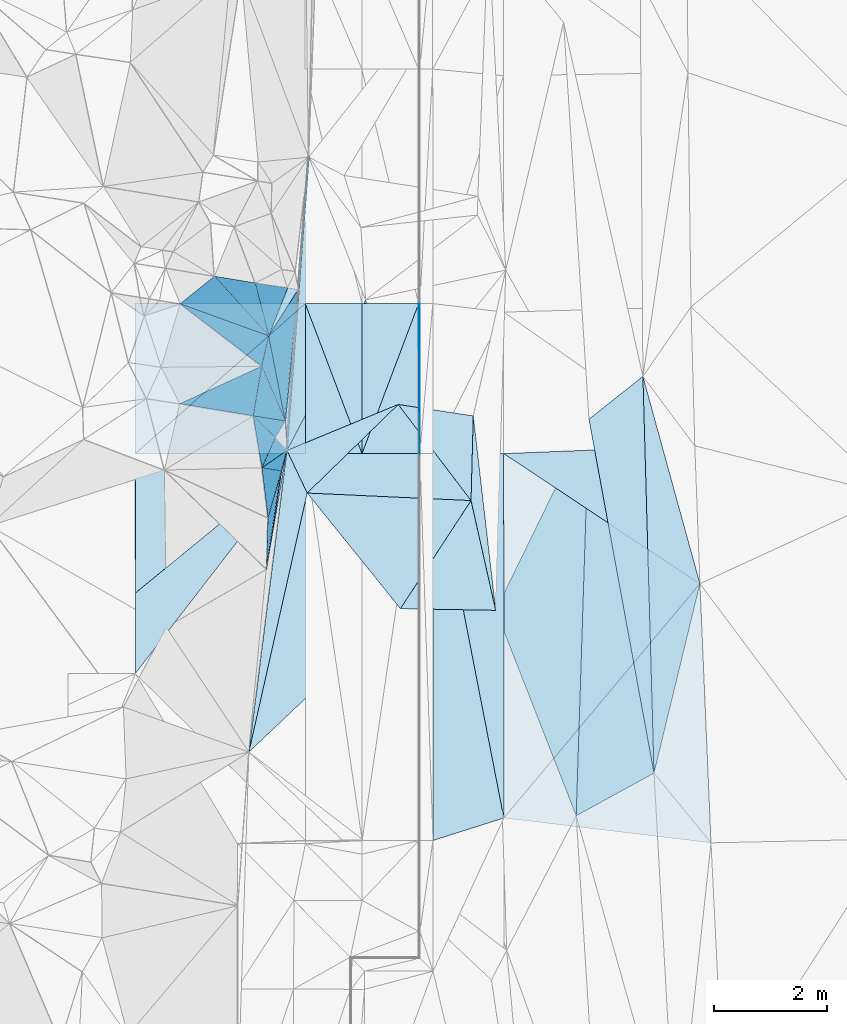
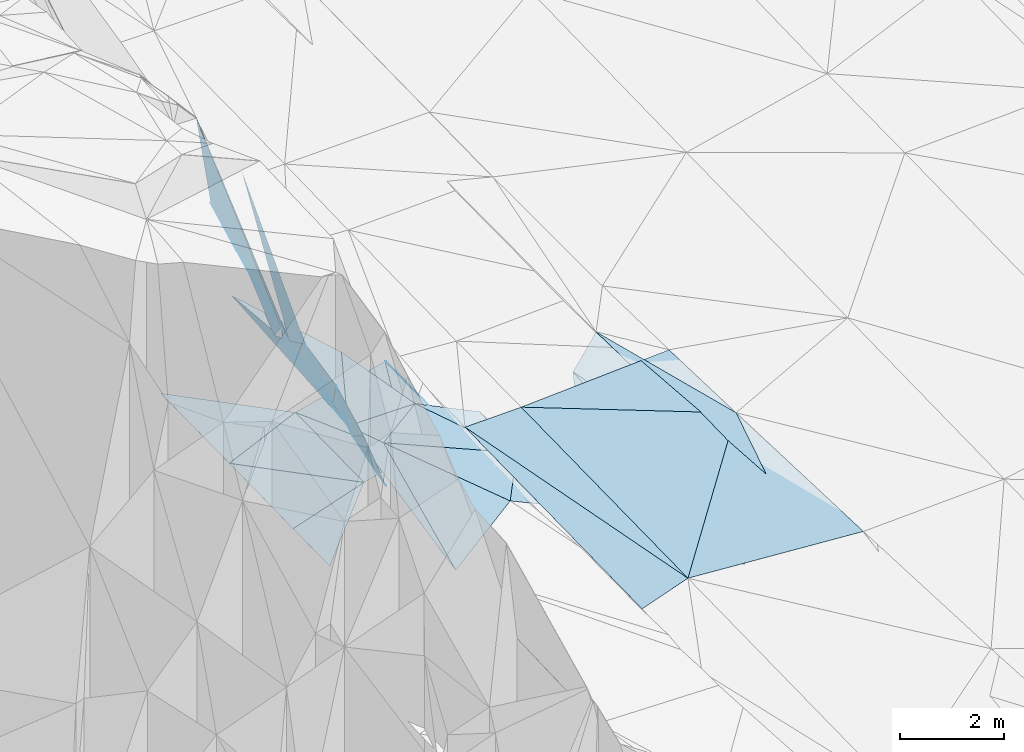
# One storey, part 130 of 275: 46 plates.
"""IFC2X3 building model written with IfcOpenShell, lengths in millimetres."""

from ifc_helpers import new_model, si_unit, frame, origin_with_axes, place, context, subcontext, project, spatial, polyline, outline, extrude, material, type_object, element, save


model = new_model("IFC2X3")

# Units and contexts
model_context = context("Model", 3, precision=1e-05, world=origin_with_axes())
body_context = subcontext(model_context, "Body", "Model", "MODEL_VIEW")
ifc_project = project(units=[si_unit("LENGTHUNIT", "METRE", prefix="MILLI"), si_unit("AREAUNIT", "SQUARE_METRE"), si_unit("VOLUMEUNIT", "CUBIC_METRE"), si_unit("MASSUNIT", "GRAM", prefix="KILO"), si_unit("TIMEUNIT", "SECOND"), si_unit("PLANEANGLEUNIT", "RADIAN"), si_unit("SOLIDANGLEUNIT", "STERADIAN"), si_unit("THERMODYNAMICTEMPERATUREUNIT", "DEGREE_CELSIUS"), si_unit("LUMINOUSINTENSITYUNIT", "LUMEN")], contexts=[model_context])

# Site, building, storey
site_placement = place(None, origin_with_axes())
site = spatial("IfcSite", under=ifc_project, at=site_placement, CompositionType="ELEMENT")
building_placement = place(site_placement, origin_with_axes())
building = spatial("IfcBuilding", under=site, at=building_placement, Name="Undefined", CompositionType="ELEMENT")
storey_placement = place(building_placement, origin_with_axes())
storey = spatial("IfcBuildingStorey", under=building, at=storey_placement, Name="Undefined", CompositionType="ELEMENT", Elevation=0.0)

# Plates
ifc_material = material()
plate_type_1 = type_object("IfcPlateType", PredefinedType="NOTDEFINED")
plate_1_placement = place(storey_placement, frame((-94153.5739844034, 105995.146812893, 43130.8232980734), z_axis=(0.0278374764460999, 0.0206402043385478, -0.999399348043602), x_axis=(-0.952600541112338, -0.302452734080232, -0.0327803709538701)))
element("IfcPlate", 1, at=plate_1_placement, inside=storey, type_object=plate_type_1, material=ifc_material, Name="00_PR", context=body_context, shape_type="SweptSolid", body=[
    extrude(outline(polyline([(0.0, 0.0), (1312.06567382813, 6.79574441164732e-09), (-754.560241699219, 6505.60107421875), (0.0, 0.0)])), frame((-8.85201319254618e-08, 2.18876761149539e-07, -0.5000001331573), z_axis=(0.0, 0.0, 1.0), x_axis=(1.0, 0.0, 0.0)), (0.0, 0.0, 1.0), 1.0),
])
plate_2_placement = place(storey_placement, frame((-95405.6369415542, 112422.818515543, 43228.6962711666), z_axis=(0.0261208683010833, 0.0203066313521981, -0.999452520614323), x_axis=(0.999658249521957, 0.000510879081040791, 0.0261366249784056)))
element("IfcPlate", 2, at=plate_2_placement, inside=storey, type_object=plate_type_1, material=ifc_material, Name="00_PR", context=body_context, shape_type="SweptSolid", body=[
    extrude(outline(polyline([(0.0, 0.0), (1250.42919921875, -1.22236087918282e-09), (1245.79235839844, 6429.634765625), (0.0, 0.0)])), frame((-8.85201319254618e-08, 2.18876761149539e-07, -0.5000001331573), z_axis=(0.0, 0.0, 1.0), x_axis=(1.0, 0.0, 0.0)), (0.0, 0.0, 1.0), 1.0),
])
plate_type_2 = type_object("IfcPlateType", PredefinedType="NOTDEFINED")
plate_3_placement = place(storey_placement, frame((-95656.4742749567, 115069.463045143, 43260.2196910795), z_axis=(0.0499247074951265, 0.0166259598819332, -0.998614590840496), x_axis=(0.998752315665235, 0.000325866070990781, 0.0499370179790064)))
element("IfcPlate", 3, at=plate_3_placement, inside=storey, type_object=plate_type_2, material=ifc_material, Name="00_PR", context=body_context, shape_type="SweptSolid", body=[
    extrude(outline(polyline([(0.0, 0.0), (20.0252170562744, 7.18500814400613e-11), (17.8119373321533, 2647.0927734375), (0.0, 0.0)])), frame((-8.85201319254618e-08, 2.18876761149539e-07, -0.5000001331573), z_axis=(0.0, 0.0, 1.0), x_axis=(1.0, 0.0, 0.0)), (0.0, 0.0, 1.0), 1.0),
])
plate_type_3 = type_object("IfcPlateType", PredefinedType="NOTDEFINED")
plate_4_placement = place(storey_placement, frame((-99872.0650010797, 113302.814362502, 50299.8591237515), z_axis=(-0.959496805873995, 0.00234955808764443, -0.281709707135544), x_axis=(0.279685924124985, 0.127877033033819, -0.951537307870175)))
element("IfcPlate", 4, at=plate_4_placement, inside=storey, type_object=plate_type_3, material=ifc_material, Name="00", context=body_context, shape_type="SweptSolid", body=[
    extrude(outline(polyline([(0.0, 0.0), (5170.580078125, 9.32777766138315e-09), (4541.27001953125, 801.042053222656), (0.0, 0.0)])), frame((-8.85201319254618e-08, 2.18876761149539e-07, -0.5000001331573), z_axis=(0.0, 0.0, 1.0), x_axis=(1.0, 0.0, 0.0)), (0.0, 0.0, 1.0), 1.0),
])
plate_type_4 = type_object("IfcPlateType", PredefinedType="NOTDEFINED")
plate_5_placement = place(storey_placement, frame((-99864.5274643564, 115066.554479282, 50459.8470441327), z_axis=(-0.932356227712419, 0.192760558500819, -0.305867997234626), x_axis=(0.290269002138026, -0.105254291932914, -0.95113902266046)))
element("IfcPlate", 5, at=plate_5_placement, inside=storey, type_object=plate_type_4, material=ifc_material, Name="00", context=body_context, shape_type="SweptSolid", body=[
    extrude(outline(polyline([(0.0, 0.0), (5383.01953125, -1.00408215075731e-08), (5365.40869140625, 551.171325683594), (0.0, 0.0)])), frame((-8.85201319254618e-08, 2.18876761149539e-07, -0.5000001331573), z_axis=(0.0, 0.0, 1.0), x_axis=(1.0, 0.0, 0.0)), (0.0, 0.0, 1.0), 1.0),
])
plate_6_placement = place(storey_placement, frame((-99259.4282691992, 115552.712917861, 47959.8037929451), z_axis=(-0.907265399754033, 0.151375251563829, -0.39237103310915), x_axis=(0.387097684267183, -0.0641139159434348, -0.919806930076841)))
element("IfcPlate", 6, at=plate_6_placement, inside=storey, type_object=plate_type_4, material=ifc_material, Name="00", context=body_context, shape_type="SweptSolid", body=[
    extrude(outline(polyline([(0.0, 0.0), (1859.08581542969, 4.30736690759659e-09), (2848.0126953125, 882.169799804688), (0.0, 0.0)])), frame((-8.85201319254618e-08, 2.18876761149539e-07, -0.5000001331573), z_axis=(0.0, 0.0, 1.0), x_axis=(1.0, 0.0, 0.0)), (0.0, 0.0, 1.0), 1.0),
])
plate_type_5 = type_object("IfcPlateType", PredefinedType="NOTDEFINED")
plate_7_placement = place(storey_placement, frame((-100655.082924783, 109962.813485595, 44165.7136786777), z_axis=(-0.442612464401428, 0.0113191605245592, -0.896641557681504), x_axis=(0.724348482389604, 0.5939477153815, -0.350064833213756)))
element("IfcPlate", 7, at=plate_7_placement, inside=storey, type_object=plate_type_5, material=ifc_material, Name="00_PR", context=body_context, shape_type="SweptSolid", body=[
    extrude(outline(polyline([(0.0, 0.0), (4140.564453125, 2.29920260608196e-08), (-836.783935546875, 1147.52770996094), (0.0, 0.0)])), frame((-8.85201319254618e-08, 2.18876761149539e-07, -0.5000001331573), z_axis=(0.0, 0.0, 1.0), x_axis=(1.0, 0.0, 0.0)), (0.0, 0.0, 1.0), 1.0),
])
plate_type_6 = type_object("IfcPlateType", PredefinedType="NOTDEFINED")
plate_8_placement = place(storey_placement, frame((-97655.8736261931, 112422.095734692, 42716.2488614941), z_axis=(-0.447143922811431, 0.0182397050018191, -0.894276034261375), x_axis=(-0.7243484823853, -0.593947715386519, 0.350064833214145)))
element("IfcPlate", 8, at=plate_8_placement, inside=storey, type_object=plate_type_6, material=ifc_material, Name="00_PR", context=body_context, shape_type="SweptSolid", body=[
    extrude(outline(polyline([(0.0, 0.0), (4140.564453125, 2.29920260608196e-08), (2698.71362304688, 1991.71862792969), (0.0, 0.0)])), frame((-8.85201319254618e-08, 2.18876761149539e-07, -0.5000001331573), z_axis=(0.0, 0.0, 1.0), x_axis=(1.0, 0.0, 0.0)), (0.0, 0.0, 1.0), 1.0),
])
plate_type_7 = type_object("IfcPlateType", PredefinedType="NOTDEFINED")
for number, where, z_axis, x_axis, name in (
    (9, (-100655.873251657, 112421.132227227, 44216.2488349393), (-0.447168887781171, 0.0147320316862256, -0.894328213265659), (0.704464317565349, 0.621909904733936, -0.341991367831139), "00_PR"),
    (10, (-97656.7219843052, 115068.820453759, 42760.2718346619), (-0.447168887781171, 0.0147320316862256, -0.894328213265659), (-0.704464318025631, -0.621909904093813, 0.341991368047072), "00_PR"),
):
    element("IfcPlate", number, at=place(storey_placement, frame(where, z_axis=z_axis, x_axis=x_axis)), inside=storey, type_object=plate_type_7, material=ifc_material, Name=name, context=body_context, shape_type="SweptSolid", body=[
        extrude(outline(polyline([(0.0, 0.0), (4257.35009765625, 1.80443748831749e-08), (2626.97778320313, 2085.42236328125), (0.0, 0.0)])), frame((-8.85201319254618e-08, 2.18876761149539e-07, -0.5000001331573), z_axis=(0.0, 0.0, 1.0), x_axis=(1.0, 0.0, 0.0)), (0.0, 0.0, 1.0), 1.0),
    ])
plate_type_8 = type_object("IfcPlateType", PredefinedType="NOTDEFINED")
for number, where, z_axis, x_axis, name in (
    (11, (-96655.5287662428, 112422.415747409, 42966.2109910744), (0.242498842736958, 0.0162120063965467, -0.97001622776108), (-0.970142403271045, -0.000311047105442569, -0.242535813077531), "00_PR"),
    (12, (-97656.3771468638, 115068.821194078, 42760.2339911808), (0.242498842736958, 0.0162120063965467, -0.97001622776108), (0.970142455388523, 0.000311440077304942, 0.242535604103411), "00_PR"),
):
    element("IfcPlate", number, at=place(storey_placement, frame(where, z_axis=z_axis, x_axis=x_axis)), inside=storey, type_object=plate_type_8, material=ifc_material, Name=name, context=body_context, shape_type="SweptSolid", body=[
        extrude(outline(polyline([(0.0, 0.0), (1030.77648925781, -5.90807758271694e-09), (1020.09808349609, 2647.07104492188), (0.0, 0.0)])), frame((-8.85201319254618e-08, 2.18876761149539e-07, -0.5000001331573), z_axis=(0.0, 0.0, 1.0), x_axis=(1.0, 0.0, 0.0)), (0.0, 0.0, 1.0), 1.0),
    ])
plate_type_9 = type_object("IfcPlateType", PredefinedType="NOTDEFINED")
plate_9_placement = place(storey_placement, frame((-95656.3779866372, 115069.462839216, 43260.2339901821), z_axis=(0.242498842736958, 0.0162120063965467, -0.97001622776108), x_axis=(0.00032097805931429, -0.999861648908334, -0.0166306949762518)))
element("IfcPlate", 13, at=plate_9_placement, inside=storey, type_object=plate_type_9, material=ifc_material, Name="00_PR", context=body_context, shape_type="SweptSolid", body=[
    extrude(outline(polyline([(0.0, 0.0), (2647.09326171875, -9.60426405072212e-09), (2651.25, 1030.7685546875), (0.0, 0.0)])), frame((-8.85201319254618e-08, 2.18876761149539e-07, -0.5000001331573), z_axis=(0.0, 0.0, 1.0), x_axis=(1.0, 0.0, 0.0)), (0.0, 0.0, 1.0), 1.0),
])
plate_10_placement = place(storey_placement, frame((-96655.5287662428, 112422.415747409, 42966.2109910744), z_axis=(0.242498842736958, 0.0162120063965467, -0.97001622776108), x_axis=(-0.000320480057325893, 0.999861649018139, 0.0166306979787731)))
element("IfcPlate", 14, at=plate_10_placement, inside=storey, type_object=plate_type_9, material=ifc_material, Name="00_PR", context=body_context, shape_type="SweptSolid", body=[
    extrude(outline(polyline([(0.0, 0.0), (2647.0927734375, 1.41153577715158e-08), (2651.25048828125, 1030.76721191406), (0.0, 0.0)])), frame((-8.85201319254618e-08, 2.18876761149539e-07, -0.5000001331573), z_axis=(0.0, 0.0, 1.0), x_axis=(1.0, 0.0, 0.0)), (0.0, 0.0, 1.0), 1.0),
])
plate_type_10 = type_object("IfcPlateType", PredefinedType="NOTDEFINED")
plate_11_placement = place(storey_placement, frame((-98574.8625320658, 113089.061324221, 45879.8370640157), z_axis=(-0.945089085803476, -0.025316928593437, -0.325830742904572), x_axis=(0.146212636792908, 0.858897229716422, -0.490833386830523)))
element("IfcPlate", 15, at=plate_11_placement, inside=storey, type_object=plate_type_10, material=ifc_material, Name="00", context=body_context, shape_type="SweptSolid", body=[
    extrude(outline(polyline([(0.0, 0.0), (1018.67559814453, -3.98722477257252e-09), (805.752075195313, 1527.79699707031), (0.0, 0.0)])), frame((-8.85201319254618e-08, 2.18876761149539e-07, -0.5000001331573), z_axis=(0.0, 0.0, 1.0), x_axis=(1.0, 0.0, 0.0)), (0.0, 0.0, 1.0), 1.0),
])
plate_type_11 = type_object("IfcPlateType", PredefinedType="NOTDEFINED")
plate_12_placement = place(storey_placement, frame((-96592.5799105062, 115135.16011891, 43769.5112733669), z_axis=(-0.210295943601626, -0.0212414963958179, -0.977406985311425), x_axis=(-0.459428561301201, -0.880344137005874, 0.117981343864573)))
element("IfcPlate", 16, at=plate_12_placement, inside=storey, type_object=plate_type_11, material=ifc_material, Name="00", context=body_context, shape_type="SweptSolid", body=[
    extrude(outline(polyline([(0.0, 0.0), (3017.42626953125, 6.66477717459202e-09), (-1736.73779296875, 2086.4150390625), (0.0, 0.0)])), frame((-8.85201319254618e-08, 2.18876761149539e-07, -0.5000001331573), z_axis=(0.0, 0.0, 1.0), x_axis=(1.0, 0.0, 0.0)), (0.0, 0.0, 1.0), 1.0),
])
plate_type_12 = type_object("IfcPlateType", PredefinedType="NOTDEFINED")
plate_13_placement = place(storey_placement, frame((-90785.0571654086, 112559.415552066, 43349.5002529591), z_axis=(0.0253446032108164, 0.0194983356069369, -0.999488602234486), x_axis=(0.0372663191023117, -0.999133250256122, -0.0185464199564918)))
element("IfcPlate", 17, at=plate_13_placement, inside=storey, type_object=plate_type_12, material=ifc_material, Name="00_PR", context=body_context, shape_type="SweptSolid", body=[
    extrude(outline(polyline([(0.0, 0.0), (2433.0302734375, 3.52156348526478e-09), (11.8660821914673, 3374.44921875), (0.0, 0.0)])), frame((-8.85201319254618e-08, 2.18876761149539e-07, -0.5000001331573), z_axis=(0.0, 0.0, 1.0), x_axis=(1.0, 0.0, 0.0)), (0.0, 0.0, 1.0), 1.0),
])
plate_type_13 = type_object("IfcPlateType", PredefinedType="NOTDEFINED")
plate_14_placement = place(storey_placement, frame((-90694.3864496484, 110128.494231487, 43304.3762713233), z_axis=(0.0266141804198783, 0.0196921245479067, -0.999451802555465), x_axis=(0.0426336240944424, -0.998918619030197, -0.0185463379506328)))
element("IfcPlate", 18, at=plate_14_placement, inside=storey, type_object=plate_type_13, material=ifc_material, Name="00_PR", context=body_context, shape_type="SweptSolid", body=[
    extrude(outline(polyline([(0.0, 0.0), (4576.42919921875, -1.27183739095926e-08), (3984.619140625, 3633.65893554688), (0.0, 0.0)])), frame((-8.85201319254618e-08, 2.18876761149539e-07, -0.5000001331573), z_axis=(0.0, 0.0, 1.0), x_axis=(1.0, 0.0, 0.0)), (0.0, 0.0, 1.0), 1.0),
])
plate_type_14 = type_object("IfcPlateType", PredefinedType="NOTDEFINED")
plate_15_placement = place(storey_placement, frame((-94153.5749686622, 105995.146645917, 43130.8232688278), z_axis=(0.0258802024209601, 0.0203066816319356, -0.99945878044257), x_axis=(-0.000320420084066932, 0.99979377701162, 0.0203051909571934)))
element("IfcPlate", 19, at=plate_15_placement, inside=storey, type_object=plate_type_14, material=ifc_material, Name="00_PR", context=body_context, shape_type="SweptSolid", body=[
    extrude(outline(polyline([(0.0, 0.0), (6429.63671875, -3.37604433298111e-08), (4134.9111328125, 3461.67260742188), (0.0, 0.0)])), frame((-8.85201319254618e-08, 2.18876761149539e-07, -0.5000001331573), z_axis=(0.0, 0.0, 1.0), x_axis=(1.0, 0.0, 0.0)), (0.0, 0.0, 1.0), 1.0),
])
plate_type_15 = type_object("IfcPlateType", PredefinedType="NOTDEFINED")
plate_16_placement = place(storey_placement, frame((-97978.9340204413, 112478.82157642, 44125.5294730019), z_axis=(-0.334843187766478, 0.0486332055852855, -0.941017986502321), x_axis=(0.459428561388022, 0.880344136960672, -0.11798134386377)))
element("IfcPlate", 20, at=plate_16_placement, inside=storey, type_object=plate_type_15, material=ifc_material, Name="00", context=body_context, shape_type="SweptSolid", body=[
    extrude(outline(polyline([(0.0, 0.0), (3017.42626953125, 6.66477717459202e-09), (1692.81384277344, 1438.81970214844), (0.0, 0.0)])), frame((-8.85201319254618e-08, 2.18876761149539e-07, -0.5000001331573), z_axis=(0.0, 0.0, 1.0), x_axis=(1.0, 0.0, 0.0)), (0.0, 0.0, 1.0), 1.0),
])
plate_type_16 = type_object("IfcPlateType", PredefinedType="NOTDEFINED")
plate_17_placement = place(storey_placement, frame((-92652.0111202408, 113030.752163405, 43197.5049582611), z_axis=(0.138826511348324, 0.0229762009720196, -0.990050147182327), x_axis=(0.77733346851035, 0.616884155337105, 0.123315115163132)))
element("IfcPlate", 21, at=plate_17_placement, inside=storey, type_object=plate_type_16, material=ifc_material, Name="00", context=body_context, shape_type="SweptSolid", body=[
    extrude(outline(polyline([(0.0, 0.0), (1224.50524902344, -2.03726813197136e-09), (-2957.46240234375, 5616.72265625), (0.0, 0.0)])), frame((-8.85201319254618e-08, 2.18876761149539e-07, -0.5000001331573), z_axis=(0.0, 0.0, 1.0), x_axis=(1.0, 0.0, 0.0)), (0.0, 0.0, 1.0), 1.0),
])
plate_type_17 = type_object("IfcPlateType", PredefinedType="NOTDEFINED")
plate_18_placement = place(storey_placement, frame((-98340.2845148116, 110382.749738385, 44109.5447867285), z_axis=(-0.406530694007643, 0.0770253109349205, -0.910384477188096), x_axis=(0.149014174744148, 0.988687050217859, 0.0171082569781417)))
element("IfcPlate", 22, at=plate_18_placement, inside=storey, type_object=plate_type_17, material=ifc_material, Name="00", context=body_context, shape_type="SweptSolid", body=[
    extrude(outline(polyline([(0.0, 0.0), (1753.53930664063, 7.18864612281322e-09), (2126.48779296875, 49.2985763549805), (0.0, 0.0)])), frame((-8.85201319254618e-08, 2.18876761149539e-07, -0.5000001331573), z_axis=(0.0, 0.0, 1.0), x_axis=(1.0, 0.0, 0.0)), (0.0, 0.0, 1.0), 1.0),
])
plate_type_18 = type_object("IfcPlateType", PredefinedType="NOTDEFINED")
plate_19_placement = place(storey_placement, frame((-98574.8693475167, 113089.064883149, 45879.8580977187), z_axis=(-0.958721781490472, -0.0182074635832901, -0.283762284254971), x_axis=(0.277657430346364, -0.275120338037737, -0.920442910218475)))
element("IfcPlate", 23, at=plate_19_placement, inside=storey, type_object=plate_type_18, material=ifc_material, Name="00", context=body_context, shape_type="SweptSolid", body=[
    extrude(outline(polyline([(0.0, 0.0), (1401.49914550781, 1.17870513349772e-09), (718.088195800781, 747.562316894531), (0.0, 0.0)])), frame((-8.85201319254618e-08, 2.18876761149539e-07, -0.5000001331573), z_axis=(0.0, 0.0, 1.0), x_axis=(1.0, 0.0, 0.0)), (0.0, 0.0, 1.0), 1.0),
])
plate_type_19 = type_object("IfcPlateType", PredefinedType="NOTDEFINED")
plate_20_placement = place(storey_placement, frame((-92877.1595835913, 106034.225951967, 42976.5244854751), z_axis=(0.308545010802131, 0.02010652025257, -0.95099721563864), x_axis=(-0.36297087160041, 0.926614423006066, -0.0981725900991369)))
element("IfcPlate", 24, at=plate_20_placement, inside=storey, type_object=plate_type_19, material=ifc_material, Name="00", context=body_context, shape_type="SweptSolid", body=[
    extrude(outline(polyline([(0.0, 0.0), (3911.47875976563, -1.40789779834449e-09), (6379.63134765625, 2889.84985351563), (0.0, 0.0)])), frame((-8.85201319254618e-08, 2.18876761149539e-07, -0.5000001331573), z_axis=(0.0, 0.0, 1.0), x_axis=(1.0, 0.0, 0.0)), (0.0, 0.0, 1.0), 1.0),
])
plate_type_20 = type_object("IfcPlateType", PredefinedType="NOTDEFINED")
plate_21_placement = place(storey_placement, frame((-96017.5315388676, 113290.189802174, 43469.5350795466), z_axis=(-0.365811047090207, 0.0407992563744219, -0.929794438844447), x_axis=(0.919308200159784, -0.139918483398742, -0.367825027862944)))
element("IfcPlate", 25, at=plate_21_placement, inside=storey, type_object=plate_type_20, material=ifc_material, Name="00", context=body_context, shape_type="SweptSolid", body=[
    extrude(outline(polyline([(0.0, 0.0), (1440.90246582031, -7.9890014603734e-09), (1631.96325683594, 1482.59765625), (0.0, 0.0)])), frame((-8.85201319254618e-08, 2.18876761149539e-07, -0.5000001331573), z_axis=(0.0, 0.0, 1.0), x_axis=(1.0, 0.0, 0.0)), (0.0, 0.0, 1.0), 1.0),
])
plate_type_21 = type_object("IfcPlateType", PredefinedType="NOTDEFINED")
plate_22_placement = place(storey_placement, frame((-97595.5603010734, 117652.80200268, 43930.9842436026), z_axis=(-0.996854226126761, 0.0727412553435288, -0.0314700115072074), x_axis=(-0.0739053306677793, -0.996557739558377, 0.0375589380199342)))
element("IfcPlate", 26, at=plate_22_placement, inside=storey, type_object=plate_type_21, material=ifc_material, Name="00", context=body_context, shape_type="SweptSolid", body=[
    extrude(outline(polyline([(0.0, 0.0), (5191.83984375, 2.86599970422685e-08), (2353.5478515625, 351.02490234375), (0.0, 0.0)])), frame((-8.85201319254618e-08, 2.18876761149539e-07, -0.5000001331573), z_axis=(0.0, 0.0, 1.0), x_axis=(1.0, 0.0, 0.0)), (0.0, 0.0, 1.0), 1.0),
])
plate_type_22 = type_object("IfcPlateType", PredefinedType="NOTDEFINED")
plate_23_placement = place(storey_placement, frame((-94692.930377967, 113088.581294238, 42939.5491483469), z_axis=(-0.430449588073284, 0.041566156733435, -0.901657033878155), x_axis=(0.114018115708891, -0.9884331813922, -0.0999985760552992)))
element("IfcPlate", 27, at=plate_23_placement, inside=storey, type_object=plate_type_22, material=ifc_material, Name="00", context=body_context, shape_type="SweptSolid", body=[
    extrude(outline(polyline([(0.0, 0.0), (3470.04931640625, -2.02417140826583e-08), (1476.72253417969, 232.14372253418), (0.0, 0.0)])), frame((-8.85201319254618e-08, 2.18876761149539e-07, -0.5000001331573), z_axis=(0.0, 0.0, 1.0), x_axis=(1.0, 0.0, 0.0)), (0.0, 0.0, 1.0), 1.0),
])
plate_type_23 = type_object("IfcPlateType", PredefinedType="NOTDEFINED")
plate_24_placement = place(storey_placement, frame((-97779.4289343345, 115321.332636335, 44369.6767922989), z_axis=(-0.755260918151799, 0.108550258871928, -0.646372792443602), x_axis=(-0.0698325407104841, -0.993903614312947, -0.0853171829913523)))
element("IfcPlate", 28, at=plate_24_placement, inside=storey, type_object=plate_type_23, material=ifc_material, Name="00", context=body_context, shape_type="SweptSolid", body=[
    extrude(outline(polyline([(0.0, 0.0), (2859.91625976563, -1.68802216649055e-08), (2333.86206054688, 104.345405578613), (0.0, 0.0)])), frame((-8.85201319254618e-08, 2.18876761149539e-07, -0.5000001331573), z_axis=(0.0, 0.0, 1.0), x_axis=(1.0, 0.0, 0.0)), (0.0, 0.0, 1.0), 1.0),
])
plate_type_24 = type_object("IfcPlateType", PredefinedType="NOTDEFINED")
plate_25_placement = place(storey_placement, frame((-98651.1864443933, 107158.703018528, 44186.5308053964), z_axis=(-0.341945161984411, 0.0508823234438664, -0.938341353323197), x_axis=(0.219504676447356, 0.975234774443729, -0.0271077799428645)))
element("IfcPlate", 29, at=plate_25_placement, inside=storey, type_object=plate_type_24, material=ifc_material, Name="00", context=body_context, shape_type="SweptSolid", body=[
    extrude(outline(polyline([(0.0, 0.0), (4685.001953125, 2.49274307861924e-08), (3076.81030273438, 2186.57739257813), (0.0, 0.0)])), frame((-8.85201319254618e-08, 2.18876761149539e-07, -0.5000001331573), z_axis=(0.0, 0.0, 1.0), x_axis=(1.0, 0.0, 0.0)), (0.0, 0.0, 1.0), 1.0),
])
plate_type_25 = type_object("IfcPlateType", PredefinedType="NOTDEFINED")
plate_26_placement = place(storey_placement, frame((-94732.404635087, 111595.084800789, 42889.5444480813), z_axis=(-0.409508484061439, 0.0477136995632734, -0.911057739309473), x_axis=(0.21682947962088, -0.964925853754735, -0.147996869977156)))
element("IfcPlate", 30, at=plate_26_placement, inside=storey, type_object=plate_type_25, material=ifc_material, Name="00", context=body_context, shape_type="SweptSolid", body=[
    extrude(outline(polyline([(0.0, 0.0), (2006.79919433594, 3.49245965480804e-09), (1501.40087890625, 1772.87780761719), (0.0, 0.0)])), frame((-8.85201319254618e-08, 2.18876761149539e-07, -0.5000001331573), z_axis=(0.0, 0.0, 1.0), x_axis=(1.0, 0.0, 0.0)), (0.0, 0.0, 1.0), 1.0),
])
plate_type_26 = type_object("IfcPlateType", PredefinedType="NOTDEFINED")
plate_27_placement = place(storey_placement, frame((-98315.4320752153, 111290.457909499, 44719.9086832143), z_axis=(-0.971737963217052, 0.149619176653051, -0.182590889204361), x_axis=(0.227832830753956, 0.796879132534022, -0.559531812645593)))
element("IfcPlate", 31, at=plate_27_placement, inside=storey, type_object=plate_type_26, material=ifc_material, Name="00", context=body_context, shape_type="SweptSolid", body=[
    extrude(outline(polyline([(0.0, 0.0), (1036.58093261719, -5.1804818212986e-09), (-387.716949462891, 1022.87609863281), (0.0, 0.0)])), frame((-8.85201319254618e-08, 2.18876761149539e-07, -0.5000001331573), z_axis=(0.0, 0.0, 1.0), x_axis=(1.0, 0.0, 0.0)), (0.0, 0.0, 1.0), 1.0),
])
plate_type_27 = type_object("IfcPlateType", PredefinedType="NOTDEFINED")
plate_28_placement = place(storey_placement, frame((-98425.8821322406, 113964.095058735, 45379.7687290755), z_axis=(-0.870782406378717, 0.166830657004934, -0.462499224458369), x_axis=(0.224695965714734, 0.971725422018755, -0.0725356959985568)))
element("IfcPlate", 32, at=plate_28_placement, inside=storey, type_object=plate_type_27, material=ifc_material, Name="00", context=body_context, shape_type="SweptSolid", body=[
    extrude(outline(polyline([(0.0, 0.0), (551.45263671875, -2.18278728425503e-09), (-761.80615234375, 1341.32446289063), (0.0, 0.0)])), frame((-8.85201319254618e-08, 2.18876761149539e-07, -0.5000001331573), z_axis=(0.0, 0.0, 1.0), x_axis=(1.0, 0.0, 0.0)), (0.0, 0.0, 1.0), 1.0),
])
plate_type_28 = type_object("IfcPlateType", PredefinedType="NOTDEFINED")
plate_29_placement = place(storey_placement, frame((-91504.6306591479, 106787.562342109, 43213.5062946761), z_axis=(0.156128117683678, 0.0261627019094133, -0.987390259166734), x_axis=(-0.866773573645972, -0.475715443406505, -0.149660913178905)))
element("IfcPlate", 33, at=plate_29_placement, inside=storey, type_object=plate_type_28, material=ifc_material, Name="00", context=body_context, shape_type="SweptSolid", body=[
    extrude(outline(polyline([(0.0, 0.0), (1583.57983398438, -7.07223080098629e-09), (-1973.07641601563, 6033.33447265625), (0.0, 0.0)])), frame((-8.85201319254618e-08, 2.18876761149539e-07, -0.5000001331573), z_axis=(0.0, 0.0, 1.0), x_axis=(1.0, 0.0, 0.0)), (0.0, 0.0, 1.0), 1.0),
])
plate_type_29 = type_object("IfcPlateType", PredefinedType="NOTDEFINED")
plate_30_placement = place(storey_placement, frame((-98539.799829707, 115433.477958885, 46249.8414987266), z_axis=(-0.945997830025853, 0.0680028800668471, -0.316960114034861), x_axis=(0.314320747177094, -0.0468051589465022, -0.948162298865561)))
element("IfcPlate", 34, at=plate_30_placement, inside=storey, type_object=plate_type_29, material=ifc_material, Name="00", context=body_context, shape_type="SweptSolid", body=[
    extrude(outline(polyline([(0.0, 0.0), (1824.58215332031, -1.07684172689915e-09), (981.265747070313, 890.683715820313), (0.0, 0.0)])), frame((-8.85201319254618e-08, 2.18876761149539e-07, -0.5000001331573), z_axis=(0.0, 0.0, 1.0), x_axis=(1.0, 0.0, 0.0)), (0.0, 0.0, 1.0), 1.0),
])
plate_type_30 = type_object("IfcPlateType", PredefinedType="NOTDEFINED")
plate_31_placement = place(storey_placement, frame((-90694.3824468972, 110128.494527365, 43309.5003946883), z_axis=(0.0348906624590167, 0.0202487149568419, -0.999185984297101), x_axis=(-0.23561399930886, -0.971445754069697, -0.0279139791080204)))
element("IfcPlate", 35, at=plate_31_placement, inside=storey, type_object=plate_type_30, material=ifc_material, Name="00", context=body_context, shape_type="SweptSolid", body=[
    extrude(outline(polyline([(0.0, 0.0), (3439.13720703125, -3.43425199389458e-09), (-3317.29370117188, 1840.39892578125), (0.0, 0.0)])), frame((-8.85201319254618e-08, 2.18876761149539e-07, -0.5000001331573), z_axis=(0.0, 0.0, 1.0), x_axis=(1.0, 0.0, 0.0)), (0.0, 0.0, 1.0), 1.0),
])
plate_type_31 = type_object("IfcPlateType", PredefinedType="NOTDEFINED")
plate_32_placement = place(storey_placement, frame((-98301.8399424985, 114499.663809261, 45339.6606488564), z_axis=(-0.604768136257926, -0.416745024954293, -0.678659771566696), x_axis=(0.27369970591578, 0.691493009004991, -0.668525159944514)))
element("IfcPlate", 36, at=plate_32_placement, inside=storey, type_object=plate_type_31, material=ifc_material, Name="00", context=body_context, shape_type="SweptSolid", body=[
    extrude(outline(polyline([(0.0, 0.0), (1226.58056640625, 5.38420863449574e-09), (1359.47033691406, 201.097763061523), (0.0, 0.0)])), frame((-8.85201319254618e-08, 2.18876761149539e-07, -0.5000001331573), z_axis=(0.0, 0.0, 1.0), x_axis=(1.0, 0.0, 0.0)), (0.0, 0.0, 1.0), 1.0),
])
plate_type_32 = type_object("IfcPlateType", PredefinedType="NOTDEFINED")
plate_33_placement = place(storey_placement, frame((-97622.7834783704, 111727.626080398, 44059.5231572929), z_axis=(-0.295627839209408, -0.0563701676208768, -0.953638602871534), x_axis=(-0.427063037469119, 0.90075143646027, 0.0791455099320874)))
element("IfcPlate", 37, at=plate_33_placement, inside=storey, type_object=plate_type_32, material=ifc_material, Name="00", context=body_context, shape_type="SweptSolid", body=[
    extrude(outline(polyline([(0.0, 0.0), (833.907043457031, -5.89352566748858e-10), (675.183166503906, 2215.99365234375), (0.0, 0.0)])), frame((-8.85201319254618e-08, 2.18876761149539e-07, -0.5000001331573), z_axis=(0.0, 0.0, 1.0), x_axis=(1.0, 0.0, 0.0)), (0.0, 0.0, 1.0), 1.0),
])
plate_type_33 = type_object("IfcPlateType", PredefinedType="NOTDEFINED")
plate_34_placement = place(storey_placement, frame((-98421.3209100434, 112172.974318134, 45419.8695474077), z_axis=(-0.961020642885587, 0.0915959569275219, -0.260862999718829), x_axis=(0.257941062305228, -0.0426172779971512, -0.965220273301884)))
element("IfcPlate", 38, at=plate_34_placement, inside=storey, type_object=plate_type_33, material=ifc_material, Name="00", context=body_context, shape_type="SweptSolid", body=[
    extrude(outline(polyline([(0.0, 0.0), (1326.12219238281, 1.76078174263239e-09), (740.580322265625, 855.360046386719), (0.0, 0.0)])), frame((-8.85201319254618e-08, 2.18876761149539e-07, -0.5000001331573), z_axis=(0.0, 0.0, 1.0), x_axis=(1.0, 0.0, 0.0)), (0.0, 0.0, 1.0), 1.0),
])
plate_type_34 = type_object("IfcPlateType", PredefinedType="NOTDEFINED")
plate_35_placement = place(storey_placement, frame((-98421.3070233101, 112173.05227065, 45419.8698150685), z_axis=(-0.933257513152582, 0.247507430159539, -0.260327651547198), x_axis=(0.315491844108835, 0.218287255025511, -0.923480140877016)))
element("IfcPlate", 39, at=plate_35_placement, inside=storey, type_object=plate_type_34, material=ifc_material, Name="00", context=body_context, shape_type="SweptSolid", body=[
    extrude(outline(polyline([(0.0, 0.0), (1401.22131347656, 4.83123585581779e-09), (1277.63549804688, 355.313323974609), (0.0, 0.0)])), frame((-8.85201319254618e-08, 2.18876761149539e-07, -0.5000001331573), z_axis=(0.0, 0.0, 1.0), x_axis=(1.0, 0.0, 0.0)), (0.0, 0.0, 1.0), 1.0),
])
plate_type_35 = type_object("IfcPlateType", PredefinedType="NOTDEFINED")
plate_36_placement = place(storey_placement, frame((-98302.0094836999, 114499.774518176, 45339.866763088), z_axis=(-0.943854981335857, -0.195326112709962, -0.266431011522879), x_axis=(-0.290269002138582, 0.105254291934901, 0.951139022660071)))
element("IfcPlate", 40, at=plate_36_placement, inside=storey, type_object=plate_type_35, material=ifc_material, Name="00", context=body_context, shape_type="SweptSolid", body=[
    extrude(outline(polyline([(0.0, 0.0), (5383.01953125, -1.00408215075731e-08), (2880.70654296875, 768.719421386719), (0.0, 0.0)])), frame((-8.85201319254618e-08, 2.18876761149539e-07, -0.5000001331573), z_axis=(0.0, 0.0, 1.0), x_axis=(1.0, 0.0, 0.0)), (0.0, 0.0, 1.0), 1.0),
])
plate_type_36 = type_object("IfcPlateType", PredefinedType="NOTDEFINED")
plate_37_placement = place(storey_placement, frame((-98574.8541683489, 113089.158778278, 45879.834611921), z_axis=(-0.928362660807125, 0.169580862821233, -0.330734184782767), x_axis=(0.326737443263041, -0.0517835759556675, -0.943695451102301)))
element("IfcPlate", 41, at=plate_37_placement, inside=storey, type_object=plate_type_36, material=ifc_material, Name="00", context=body_context, shape_type="SweptSolid", body=[
    extrude(outline(polyline([(0.0, 0.0), (1727.25219726563, 3.49245965480804e-10), (1364.47937011719, 319.99365234375), (0.0, 0.0)])), frame((-8.85201319254618e-08, 2.18876761149539e-07, -0.5000001331573), z_axis=(0.0, 0.0, 1.0), x_axis=(1.0, 0.0, 0.0)), (0.0, 0.0, 1.0), 1.0),
])
plate_type_37 = type_object("IfcPlateType", PredefinedType="NOTDEFINED")
plate_38_placement = place(storey_placement, frame((-98185.7172364481, 112703.426502299, 44589.8257584141), z_axis=(-0.927831672691645, -0.13310554516709, -0.348441244682651), x_axis=(0.371809366071716, -0.404597297691488, -0.835499145422719)))
element("IfcPlate", 42, at=plate_38_placement, inside=storey, type_object=plate_type_37, material=ifc_material, Name="00", context=body_context, shape_type="SweptSolid", body=[
    extrude(outline(polyline([(0.0, 0.0), (555.356628417969, 1.78988557308912e-09), (-566.392822265625, 839.701843261719), (0.0, 0.0)])), frame((-8.85201319254618e-08, 2.18876761149539e-07, -0.5000001331573), z_axis=(0.0, 0.0, 1.0), x_axis=(1.0, 0.0, 0.0)), (0.0, 0.0, 1.0), 1.0),
])
plate_type_38 = type_object("IfcPlateType", PredefinedType="NOTDEFINED")
plate_39_placement = place(storey_placement, frame((-98301.9931583717, 114499.92776378, 45339.8016371944), z_axis=(-0.911200242913161, 0.111158867010518, -0.396683530789892), x_axis=(0.380193667981519, 0.597706492105239, -0.70583264597354)))
element("IfcPlate", 43, at=plate_39_placement, inside=storey, type_object=plate_type_38, material=ifc_material, Name="00", context=body_context, shape_type="SweptSolid", body=[
    extrude(outline(polyline([(0.0, 0.0), (1374.26342773438, -1.68802216649055e-09), (-16.5179386138916, 1877.10607910156), (0.0, 0.0)])), frame((-8.85201319254618e-08, 2.18876761149539e-07, -0.5000001331573), z_axis=(0.0, 0.0, 1.0), x_axis=(1.0, 0.0, 0.0)), (0.0, 0.0, 1.0), 1.0),
])
plate_type_39 = type_object("IfcPlateType", PredefinedType="NOTDEFINED")
plate_40_placement = place(storey_placement, frame((-98651.0971155718, 107158.682241144, 44186.5067076879), z_axis=(-0.163196472800818, 0.00930977580331012, -0.986549663899322), x_axis=(0.125354769489568, 0.992046771871279, -0.0113747169631423)))
element("IfcPlate", 44, at=plate_40_placement, inside=storey, type_object=plate_type_39, material=ifc_material, Name="00", context=body_context, shape_type="SweptSolid", body=[
    extrude(outline(polyline([(0.0, 0.0), (5362.77099609375, -1.67055986821651e-08), (4662.99560546875, 453.558349609375), (0.0, 0.0)])), frame((-8.85201319254618e-08, 2.18876761149539e-07, -0.5000001331573), z_axis=(0.0, 0.0, 1.0), x_axis=(1.0, 0.0, 0.0)), (0.0, 0.0, 1.0), 1.0),
])
plate_type_40 = type_object("IfcPlateType", PredefinedType="NOTDEFINED")
plate_41_placement = place(storey_placement, frame((-95977.9006489589, 109688.662221587, 43349.5364413537), z_axis=(-0.374306188735324, 0.0208512044531726, -0.927070711621982), x_axis=(-0.606021773650066, 0.751208730763175, 0.261578004975968)))
element("IfcPlate", 45, at=plate_41_placement, inside=storey, type_object=plate_type_40, material=ifc_material, Name="00", context=body_context, shape_type="SweptSolid", body=[
    extrude(outline(polyline([(0.0, 0.0), (2714.29541015625, -8.59290594235063e-09), (556.976928710938, 2255.45483398438), (0.0, 0.0)])), frame((-8.85201319254618e-08, 2.18876761149539e-07, -0.5000001331573), z_axis=(0.0, 0.0, 1.0), x_axis=(1.0, 0.0, 0.0)), (0.0, 0.0, 1.0), 1.0),
])
plate_type_41 = type_object("IfcPlateType", PredefinedType="NOTDEFINED")
plate_42_placement = place(storey_placement, frame((-96017.535461373, 113290.18634045, 43469.5365028792), z_axis=(-0.373658830887692, 0.0338753135454681, -0.926947431752114), x_axis=(0.582871365685905, -0.768806085828357, -0.263055456998575)))
element("IfcPlate", 46, at=plate_42_placement, inside=storey, type_object=plate_type_41, material=ifc_material, Name="00", context=body_context, shape_type="SweptSolid", body=[
    extrude(outline(polyline([(0.0, 0.0), (2204.85815429688, 1.00226316135377e-09), (110.392585754395, 2313.93896484375), (0.0, 0.0)])), frame((-8.85201319254618e-08, 2.18876761149539e-07, -0.5000001331573), z_axis=(0.0, 0.0, 1.0), x_axis=(1.0, 0.0, 0.0)), (0.0, 0.0, 1.0), 1.0),
])

save(model, "model.ifc")
